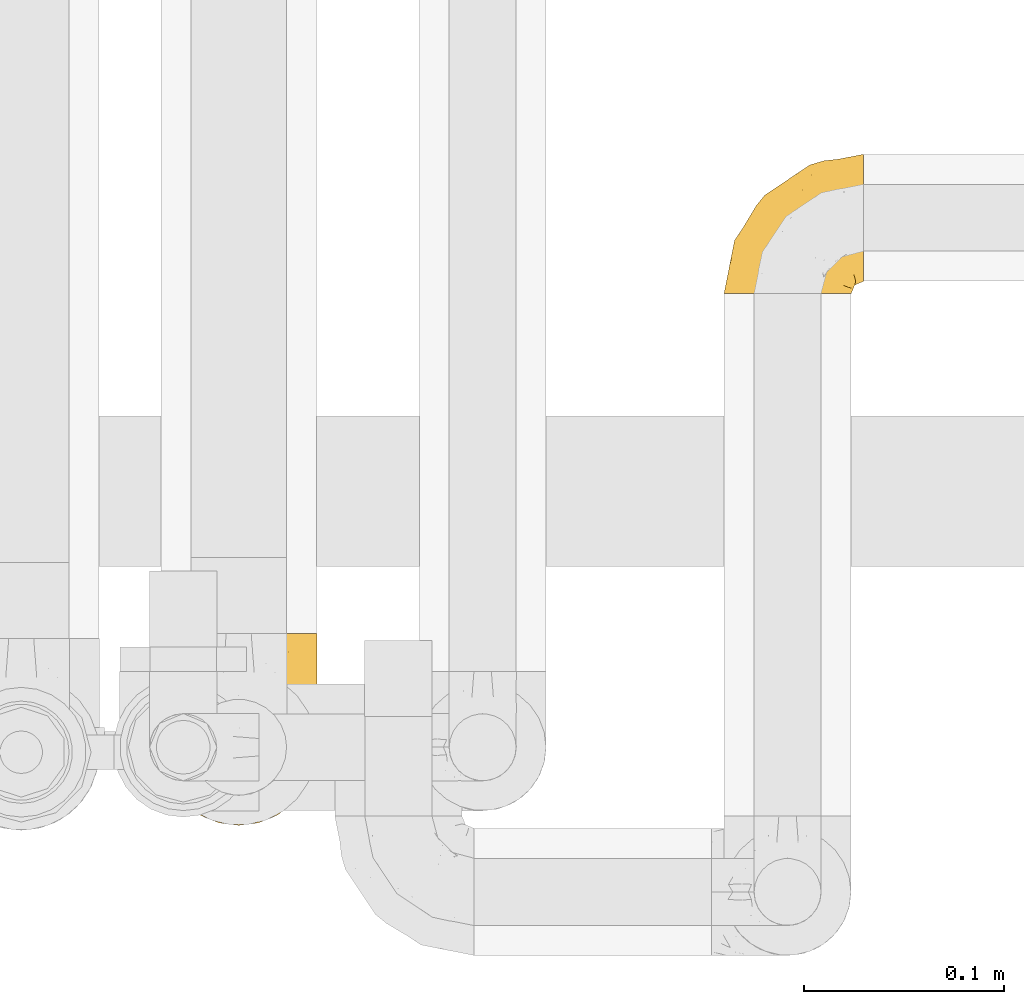
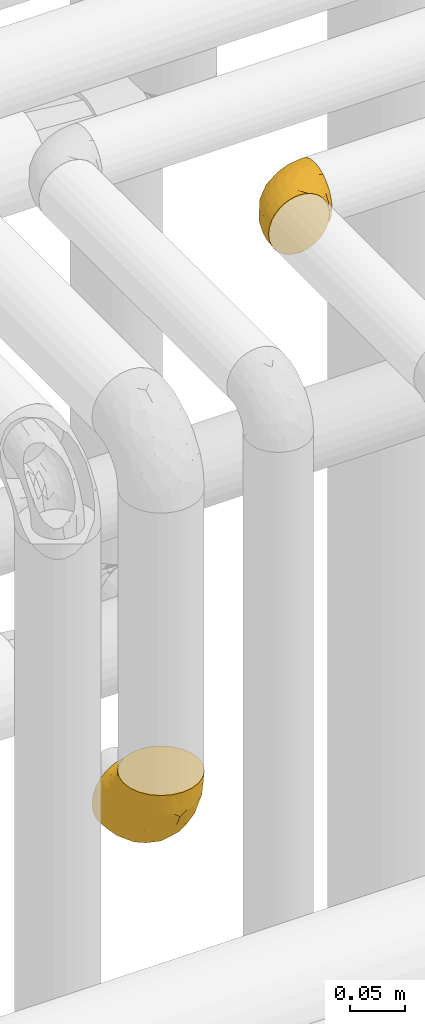
# One storey, part 450 of 827: 2 coverings.
"""IFC2X3 building model written with IfcOpenShell, lengths in millimetres."""

from ifc_helpers import new_model, entity, si_unit, converted_unit, derived_unit, direction, frame, origin, place, context, subcontext, project, spatial, faceted_brep, element, save


model = new_model("IFC2X3")

# Units and contexts
model_context = context("Model", 3, precision=0.01, world=origin(), true_north=direction((6.12303176911189e-17, 1.0)))
body_context = subcontext(model_context, "Body", "Model", "MODEL_VIEW")
ifc_project = project(units=[si_unit("LENGTHUNIT", "METRE", prefix="MILLI"), si_unit("AREAUNIT", "SQUARE_METRE"), si_unit("VOLUMEUNIT", "CUBIC_METRE"), converted_unit("PLANEANGLEUNIT", "DEGREE", entity("IfcRatioMeasure", 0.0174532925199433), si_unit("PLANEANGLEUNIT", "RADIAN"), dimensions=[0, 0, 0, 0, 0, 0, 0]), si_unit("MASSUNIT", "GRAM", prefix="KILO"), derived_unit("MASSDENSITYUNIT", [(si_unit("MASSUNIT", "GRAM", prefix="KILO"), 1), (si_unit("LENGTHUNIT", "METRE"), -3)]), derived_unit("MOMENTOFINERTIAUNIT", [(si_unit("LENGTHUNIT", "METRE"), 4)]), si_unit("TIMEUNIT", "SECOND"), si_unit("FREQUENCYUNIT", "HERTZ"), si_unit("THERMODYNAMICTEMPERATUREUNIT", "DEGREE_CELSIUS"), derived_unit("THERMALTRANSMITTANCEUNIT", [(si_unit("MASSUNIT", "GRAM", prefix="KILO"), 1), (si_unit("THERMODYNAMICTEMPERATUREUNIT", "KELVIN"), -1), (si_unit("TIMEUNIT", "SECOND"), -3)]), derived_unit("VOLUMETRICFLOWRATEUNIT", [(si_unit("LENGTHUNIT", "METRE"), 3), (si_unit("TIMEUNIT", "SECOND"), -1)]), derived_unit("MASSFLOWRATEUNIT", [(si_unit("MASSUNIT", "GRAM", prefix="KILO"), 1), (si_unit("TIMEUNIT", "SECOND"), -1)]), derived_unit("ROTATIONALFREQUENCYUNIT", [(si_unit("TIMEUNIT", "SECOND"), -1)]), si_unit("ELECTRICCURRENTUNIT", "AMPERE"), si_unit("ELECTRICVOLTAGEUNIT", "VOLT"), si_unit("POWERUNIT", "WATT"), si_unit("FORCEUNIT", "NEWTON", prefix="KILO"), si_unit("ILLUMINANCEUNIT", "LUX"), si_unit("LUMINOUSFLUXUNIT", "LUMEN"), si_unit("LUMINOUSINTENSITYUNIT", "CANDELA"), derived_unit("USERDEFINED", [(si_unit("MASSUNIT", "GRAM", prefix="KILO"), -1), (si_unit("LENGTHUNIT", "METRE"), -2), (si_unit("TIMEUNIT", "SECOND"), 3), (si_unit("LUMINOUSFLUXUNIT", "LUMEN"), 1)]), derived_unit("LINEARVELOCITYUNIT", [(si_unit("LENGTHUNIT", "METRE"), 1), (si_unit("TIMEUNIT", "SECOND"), -1)]), si_unit("PRESSUREUNIT", "PASCAL"), derived_unit("USERDEFINED", [(si_unit("LENGTHUNIT", "METRE"), -2), (si_unit("MASSUNIT", "GRAM", prefix="KILO"), 1), (si_unit("TIMEUNIT", "SECOND"), -2)]), derived_unit("LINEARFORCEUNIT", [(si_unit("MASSUNIT", "GRAM", prefix="KILO"), 1), (si_unit("LENGTHUNIT", "METRE"), 1), (si_unit("TIMEUNIT", "SECOND"), -2), (si_unit("LENGTHUNIT", "METRE"), -1)]), derived_unit("PLANARFORCEUNIT", [(si_unit("MASSUNIT", "GRAM", prefix="KILO"), 1), (si_unit("LENGTHUNIT", "METRE"), 1), (si_unit("TIMEUNIT", "SECOND"), -2), (si_unit("LENGTHUNIT", "METRE"), -2)])], contexts=[model_context])

# Site, building, storey
site_placement = place(None, origin())
site = spatial("IfcSite", under=ifc_project, at=site_placement, CompositionType="ELEMENT")
building_placement = place(site_placement, origin())
building = spatial("IfcBuilding", under=site, at=building_placement, CompositionType="ELEMENT")
storey_placement = place(building_placement, frame((0.0, 0.0, 28200.0)))
storey = spatial("IfcBuildingStorey", under=building, at=storey_placement, Name="08", CompositionType="ELEMENT", Elevation=28200.0)

# Coverings
covering_1_placement = place(storey_placement, frame((55802.39, 16229.69, 2734.25)))
element("IfcCovering", 1, at=covering_1_placement, inside=storey, Name=":ADSK_", ObjectType=":ADSK_", PredefinedType="INSULATION", context=body_context, shape_type="Brep", body=[
    faceted_brep([(79.9, 97.75, 40.75), (78.91, 97.75, 32.03), (76.02, 97.75, 23.75), (71.35, 97.75, 16.33), (65.15, 97.75, 10.13), (57.73, 97.75, 5.47), (49.45, 97.75, 2.58), (40.75, 97.75, 1.6), (32.03, 97.75, 2.58), (23.75, 97.75, 5.48), (16.33, 97.75, 10.14), (10.13, 97.75, 16.34), (5.47, 97.75, 23.76), (2.58, 97.75, 32.04), (1.6, 97.75, 40.75), (1.96, 97.75, 43.94), (2.58, 97.75, 49.46), (4.03, 97.75, 53.6), (5.48, 97.75, 57.74), (10.14, 97.75, 65.16), (16.34, 97.75, 71.36), (23.76, 97.75, 76.02), (32.04, 97.75, 78.91), (40.75, 97.75, 79.9), (49.46, 97.75, 78.91), (57.74, 97.75, 76.02), (65.16, 97.75, 71.35), (71.36, 97.75, 65.15), (76.02, 97.75, 57.73), (78.91, 97.75, 49.45), (79.54, 97.75, 43.94), (13.06, 68.43, 97.75), (6.84, 60.32, 97.75), (2.93, 50.88, 97.75), (2.44, 47.16, 97.75), (2.02, 43.95, 97.75), (1.6, 40.75, 97.75), (2.93, 30.61, 97.75), (6.84, 21.17, 97.75), (13.06, 13.06, 97.75), (21.17, 6.84, 97.75), (30.61, 2.93, 97.75), (40.75, 1.6, 97.75), (50.88, 2.93, 97.75), (60.32, 6.84, 97.75), (68.43, 13.06, 97.75), (74.65, 21.17, 97.75), (78.56, 30.61, 97.75), (79.9, 40.75, 97.75), (79.05, 47.16, 97.75), (78.56, 50.88, 97.75), (74.65, 60.32, 97.75), (68.43, 68.43, 97.75), (60.32, 74.65, 97.75), (50.88, 78.56, 97.75), (40.75, 79.9, 97.75), (30.61, 78.56, 97.75), (21.17, 74.65, 97.75), (40.75, 30.59, 30.59), (40.75, 41.23, 19.96), (53.99, 31.39, 31.39), (40.75, 19.96, 41.23), (40.75, 6.3, 68.03), (47.49, 5.21, 73.86), (40.75, 4.64, 78.49), (51.52, 15.42, 51.06), (61.86, 15.6, 61.05), (54.43, 6.88, 74.96), (63.37, 10.45, 80.64), (79.25, 80.79, 35.94), (77.04, 39.87, 55.44), (75.79, 25.91, 78.19), (72.61, 28.57, 58.08), (78.93, 35.0, 78.4), (70.12, 18.15, 74.65), (66.7, 74.57, 14.61), (72.7, 80.38, 20.05), (70.21, 59.65, 24.25), (78.8, 59.36, 43.81), (79.9, 75.93, 45.08), (79.9, 71.31, 48.17), (79.9, 66.69, 51.26), (79.9, 62.06, 54.35), (79.9, 57.44, 57.44), (74.44, 46.63, 40.25), (52.47, 74.83, 6.22), (79.33, 45.67, 61.23), (79.9, 54.35, 62.06), (79.9, 51.26, 66.69), (79.9, 48.17, 71.31), (79.9, 45.08, 75.93), (48.94, 54.03, 13.08), (58.78, 58.15, 14.98), (60.43, 80.8, 8.5), (40.75, 78.49, 4.64), (62.02, 31.82, 36.67), (57.53, 43.52, 22.97), (79.9, 94.17, 41.46), (79.9, 90.6, 42.17), (79.9, 83.46, 43.59), (64.12, 47.16, 25.24), (75.76, 64.11, 31.25), (76.65, 81.54, 26.96), (68.92, 38.43, 38.0), (66.73, 25.45, 50.65), (40.75, 13.13, 54.63), (40.75, 68.03, 6.3), (79.9, 43.59, 83.46), (79.9, 42.88, 87.03), (79.9, 42.17, 90.6), (40.75, 54.63, 13.13), (63.86, 73.05, 91.79), (69.15, 69.6, 87.2), (78.65, 51.66, 87.5), (72.98, 63.89, 89.79), (76.47, 57.82, 88.45), (76.82, 59.13, 81.77), (79.05, 52.25, 79.81), (79.09, 54.86, 73.84), (51.28, 79.38, 91.84), (51.03, 82.07, 86.62), (40.75, 85.12, 85.12), (40.75, 82.63, 91.15), (49.93, 89.2, 80.84), (58.53, 86.06, 78.96), (69.86, 81.78, 71.38), (65.19, 81.63, 76.81), (70.75, 76.19, 74.29), (79.25, 90.86, 48.29), (79.11, 85.89, 49.97), (57.89, 76.5, 92.85), (55.93, 92.32, 77.55), (78.06, 70.11, 62.05), (75.39, 69.83, 70.85), (78.16, 65.67, 65.52), (66.62, 76.0, 80.71), (73.14, 68.84, 77.97), (71.07, 91.37, 66.14), (78.32, 76.37, 57.01), (73.93, 83.17, 64.57), (77.25, 85.98, 56.53), (79.26, 79.95, 51.07), (60.3, 81.01, 81.85), (40.75, 91.15, 82.63), (65.72, 88.52, 72.53), (74.5, 75.86, 67.69), (60.62, 77.41, 86.44), (73.96, 64.86, 82.44), (77.3, 60.69, 75.97), (77.83, 62.7, 70.39), (23.6, 76.5, 92.85), (17.57, 73.85, 88.99), (1.6, 94.17, 41.46), (1.6, 90.6, 42.17), (1.6, 83.46, 43.59), (31.57, 89.2, 80.84), (22.97, 86.06, 78.97), (25.57, 92.32, 77.55), (15.78, 88.52, 72.54), (1.6, 43.59, 83.46), (1.6, 42.17, 90.6), (1.6, 41.46, 94.17), (12.34, 69.6, 87.2), (7.57, 64.84, 82.6), (8.85, 64.5, 89.34), (2.63, 52.81, 80.74), (4.67, 59.13, 81.77), (2.36, 54.5, 74.04), (1.6, 45.08, 75.93), (2.84, 51.66, 87.5), (2.24, 79.95, 51.07), (1.6, 71.31, 48.17), (3.18, 76.38, 57.03), (10.74, 76.18, 74.31), (15.18, 76.44, 80.61), (16.42, 81.43, 77.09), (30.21, 79.38, 91.84), (9.98, 70.71, 79.19), (30.46, 82.07, 86.62), (10.43, 91.37, 66.15), (12.05, 81.89, 71.84), (4.24, 85.98, 56.55), (7.56, 83.17, 64.59), (3.43, 70.11, 62.05), (2.38, 85.9, 49.99), (1.6, 75.93, 45.08), (3.66, 62.7, 70.39), (4.45, 61.23, 76.36), (6.98, 75.83, 67.71), (6.12, 69.82, 70.92), (5.38, 58.44, 89.33), (21.58, 81.13, 82.04), (3.35, 65.71, 65.56), (1.6, 62.06, 54.35), (20.87, 77.41, 86.44), (1.6, 54.35, 62.06), (1.6, 57.44, 57.44), (1.6, 48.17, 71.31), (1.6, 51.26, 66.69), (1.6, 66.69, 51.26), (2.16, 45.67, 61.23), (11.37, 18.15, 74.65), (5.7, 25.91, 78.19), (8.88, 28.58, 58.07), (12.57, 38.43, 38.01), (7.04, 46.64, 40.25), (11.27, 59.66, 24.26), (17.36, 47.16, 25.25), (2.69, 59.36, 43.81), (2.56, 35.0, 78.4), (34.0, 5.21, 73.86), (27.06, 6.88, 74.96), (4.45, 39.88, 55.45), (5.73, 64.12, 31.26), (18.12, 10.45, 80.64), (19.63, 15.6, 61.05), (27.49, 31.39, 31.39), (19.46, 31.82, 36.69), (2.24, 80.8, 35.95), (29.01, 74.83, 6.22), (14.78, 74.57, 14.62), (32.55, 54.02, 13.09), (8.78, 80.38, 20.06), (29.98, 15.42, 51.06), (23.95, 43.52, 22.97), (22.7, 58.15, 14.99), (21.05, 80.8, 8.51), (14.75, 25.47, 50.64), (4.84, 81.54, 26.97)], [[[0, 1, 2, 3, 4, 5, 6, 7, 8, 9, 10, 11, 12, 13, 14, 15, 16, 17, 18, 19, 20, 21, 22, 23, 24, 25, 26, 27, 28, 29, 30]], [[31, 32, 33, 34, 35, 36, 37, 38, 39, 40, 41, 42, 43, 44, 45, 46, 47, 48, 49, 50, 51, 52, 53, 54, 55, 56, 57]], [[58, 59, 60, 61]], [[62, 63, 64]], [[65, 66, 67]], [[67, 66, 68]], [[69, 1, 0]], [[70, 71, 72]], [[44, 43, 67]], [[47, 71, 73]], [[45, 74, 46]], [[68, 45, 44]], [[75, 76, 77]], [[76, 3, 2]], [[78, 79, 80, 81, 82, 83]], [[48, 47, 73]], [[70, 72, 84]], [[5, 85, 6]], [[86, 83, 87, 88, 89, 90]], [[91, 85, 92]], [[76, 75, 3]], [[71, 46, 74]], [[85, 5, 93]], [[45, 68, 74]], [[5, 4, 93]], [[85, 94, 6]], [[86, 78, 83]], [[60, 95, 65]], [[96, 95, 60]], [[75, 4, 3]], [[69, 0, 97, 98, 99, 79]], [[75, 77, 100]], [[43, 64, 63]], [[101, 102, 69]], [[101, 76, 102]], [[46, 71, 47]], [[95, 103, 104]], [[92, 85, 93]], [[63, 105, 65]], [[92, 75, 100]], [[91, 106, 85]], [[84, 78, 70]], [[67, 68, 44]], [[65, 67, 63]], [[65, 61, 60]], [[4, 75, 93]], [[92, 93, 75]], [[102, 76, 2]], [[77, 76, 101]], [[84, 77, 101]], [[77, 103, 100]], [[72, 71, 74]], [[70, 86, 73]], [[104, 74, 66]], [[84, 72, 103]], [[70, 73, 71]], [[73, 90, 107, 108, 109, 48]], [[79, 78, 69]], [[101, 69, 78]], [[91, 92, 96]], [[91, 59, 110, 106]], [[2, 1, 102]], [[69, 102, 1]], [[94, 85, 106]], [[94, 7, 6]], [[74, 68, 66]], [[43, 42, 64]], [[43, 63, 67]], [[73, 86, 90]], [[78, 86, 70]], [[95, 100, 103]], [[96, 92, 100]], [[104, 103, 72]], [[65, 95, 66]], [[74, 104, 72]], [[66, 95, 104]], [[95, 96, 100]], [[91, 96, 60]], [[77, 84, 103]], [[78, 84, 101]], [[60, 59, 91]], [[105, 63, 62]], [[105, 61, 65]], [[111, 52, 112]], [[107, 90, 113]], [[114, 115, 116]], [[50, 107, 113]], [[117, 118, 116]], [[54, 119, 55]], [[97, 0, 30, 29, 98]], [[113, 115, 51]], [[120, 121, 122]], [[123, 120, 124]], [[125, 126, 127]], [[128, 28, 129]], [[130, 54, 53]], [[25, 24, 131]], [[132, 133, 134]], [[135, 112, 136]], [[137, 27, 26]], [[121, 120, 123]], [[138, 139, 132]], [[129, 140, 141]], [[135, 126, 142]], [[27, 140, 28]], [[27, 137, 140]], [[49, 48, 109, 108, 107, 50]], [[23, 143, 121, 123]], [[25, 131, 144]], [[26, 25, 144]], [[128, 98, 29]], [[125, 127, 145]], [[146, 130, 111]], [[137, 144, 139]], [[139, 138, 140]], [[116, 147, 114]], [[123, 124, 131]], [[116, 118, 148]], [[138, 132, 81]], [[129, 79, 99]], [[54, 130, 119]], [[141, 79, 129]], [[122, 55, 119]], [[120, 146, 142]], [[117, 113, 90]], [[50, 113, 51]], [[127, 133, 145]], [[147, 136, 112]], [[136, 133, 127]], [[24, 23, 123]], [[118, 117, 89]], [[149, 87, 134]], [[144, 131, 124]], [[24, 123, 131]], [[128, 129, 99]], [[28, 140, 129]], [[144, 137, 26]], [[140, 137, 139]], [[134, 82, 132]], [[138, 80, 141]], [[89, 88, 87, 118]], [[115, 117, 116]], [[140, 138, 141]], [[148, 118, 149]], [[136, 148, 149]], [[147, 116, 148]], [[133, 136, 149]], [[127, 126, 135]], [[136, 147, 148]], [[114, 112, 52]], [[112, 114, 147]], [[51, 114, 52]], [[51, 115, 114]], [[117, 115, 113]], [[117, 90, 89]], [[134, 133, 149]], [[145, 133, 132]], [[132, 139, 145]], [[125, 139, 144]], [[139, 125, 145]], [[126, 144, 124]], [[144, 126, 125]], [[142, 126, 124]], [[120, 142, 124]], [[142, 146, 135]], [[112, 135, 146]], [[136, 127, 135]], [[118, 87, 149]], [[111, 130, 53]], [[119, 146, 120]], [[146, 119, 130]], [[122, 119, 120]], [[52, 111, 53]], [[146, 111, 112]], [[82, 134, 83]], [[82, 81, 132]], [[83, 134, 87]], [[98, 128, 99]], [[80, 138, 81]], [[80, 79, 141]], [[28, 128, 29]], [[150, 151, 57]], [[15, 14, 152, 153, 154, 16]], [[121, 143, 23, 155]], [[150, 57, 56]], [[156, 157, 158]], [[35, 34, 33, 159, 160, 161, 36]], [[162, 31, 57]], [[163, 164, 162]], [[165, 166, 167]], [[155, 23, 22]], [[168, 159, 169]], [[170, 171, 172]], [[173, 174, 175]], [[55, 122, 176]], [[177, 174, 173]], [[22, 157, 155]], [[178, 121, 155]], [[169, 33, 32]], [[20, 19, 179]], [[21, 20, 158]], [[158, 180, 175]], [[181, 182, 179]], [[172, 183, 182]], [[122, 121, 178]], [[181, 19, 18]], [[184, 185, 170]], [[17, 154, 184]], [[186, 187, 177]], [[187, 186, 167]], [[179, 158, 20]], [[21, 157, 22]], [[175, 180, 173]], [[188, 189, 173]], [[164, 166, 190]], [[185, 184, 154]], [[181, 172, 182]], [[156, 191, 178]], [[192, 183, 193]], [[178, 176, 122]], [[194, 150, 176]], [[33, 169, 159]], [[190, 169, 32]], [[189, 192, 186]], [[180, 188, 173]], [[167, 166, 187]], [[166, 164, 163]], [[195, 192, 196]], [[158, 157, 21]], [[155, 157, 156]], [[178, 155, 156]], [[181, 18, 184]], [[17, 16, 154]], [[181, 179, 19]], [[158, 179, 182]], [[170, 181, 184]], [[192, 195, 186]], [[31, 190, 32]], [[165, 190, 166]], [[190, 31, 164]], [[31, 162, 164]], [[177, 163, 162]], [[187, 166, 163]], [[151, 174, 177]], [[177, 173, 189]], [[177, 187, 163]], [[195, 167, 186]], [[165, 197, 168]], [[165, 168, 169]], [[167, 197, 165]], [[190, 165, 169]], [[167, 195, 198, 197]], [[151, 177, 162]], [[175, 191, 156]], [[191, 174, 194]], [[158, 175, 156]], [[174, 191, 175]], [[178, 191, 194]], [[158, 182, 180]], [[188, 182, 183]], [[182, 188, 180]], [[183, 192, 189]], [[183, 189, 188]], [[177, 189, 186]], [[183, 199, 193]], [[176, 150, 56]], [[151, 150, 194]], [[176, 56, 55]], [[194, 176, 178]], [[174, 151, 194]], [[57, 151, 162]], [[199, 183, 172]], [[196, 192, 193]], [[171, 199, 172]], [[172, 181, 170]], [[170, 185, 171]], [[184, 18, 17]], [[200, 168, 197, 198, 195, 196]], [[201, 202, 203]], [[204, 203, 205]], [[204, 206, 207]], [[208, 196, 193, 199, 171, 185]], [[209, 36, 161, 160, 159, 168]], [[202, 38, 37]], [[201, 38, 202]], [[210, 41, 211]], [[200, 208, 212]], [[205, 208, 213]], [[214, 211, 40]], [[40, 211, 41]], [[214, 201, 215]], [[58, 61, 216, 59]], [[201, 39, 38]], [[207, 217, 204]], [[213, 208, 218]], [[218, 185, 154, 153, 152, 14]], [[14, 13, 218]], [[9, 8, 219]], [[10, 220, 11]], [[221, 106, 110, 59]], [[219, 8, 94]], [[220, 222, 11]], [[223, 211, 215]], [[221, 216, 224]], [[225, 219, 221]], [[10, 9, 226]], [[213, 222, 206]], [[226, 9, 219]], [[106, 219, 94]], [[212, 202, 209]], [[201, 203, 227]], [[226, 225, 220]], [[207, 206, 220]], [[214, 40, 39]], [[11, 222, 12]], [[12, 222, 228]], [[41, 210, 64]], [[223, 105, 210]], [[223, 215, 217]], [[105, 62, 210]], [[206, 222, 220]], [[228, 222, 213]], [[207, 220, 225]], [[205, 206, 204]], [[225, 226, 219]], [[220, 10, 226]], [[209, 202, 37]], [[203, 202, 212]], [[205, 203, 212]], [[204, 217, 227]], [[36, 209, 37]], [[209, 168, 200]], [[218, 13, 228]], [[208, 185, 218]], [[106, 221, 219]], [[221, 59, 216]], [[218, 228, 213]], [[13, 12, 228]], [[8, 7, 94]], [[201, 214, 39]], [[211, 214, 215]], [[64, 210, 62]], [[64, 42, 41]], [[223, 210, 211]], [[208, 200, 196]], [[209, 200, 212]], [[225, 224, 207]], [[207, 224, 217]], [[223, 217, 216]], [[204, 227, 203]], [[217, 215, 227]], [[201, 227, 215]], [[221, 224, 225]], [[217, 224, 216]], [[208, 205, 212]], [[206, 205, 213]], [[216, 61, 223]], [[223, 61, 105]]]),
])
covering_2_placement = place(storey_placement, frame((56084.69, 16496.1, 3166.55)))
element("IfcCovering", 2, at=covering_2_placement, inside=storey, Name=":ADSK_", ObjectType=":ADSK_", PredefinedType="INSULATION", context=body_context, shape_type="Brep", body=[
    faceted_brep([(2.39, 1.6, 40.53), (1.6, 1.6, 33.45), (2.39, 1.6, 26.35), (4.75, 1.6, 19.62), (8.55, 1.6, 13.58), (13.59, 1.6, 8.54), (19.63, 1.6, 4.75), (26.36, 1.6, 2.39), (33.45, 1.6, 1.6), (37.35, 1.6, 2.04), (40.54, 1.6, 2.39), (43.9, 1.6, 3.57), (47.27, 1.6, 4.75), (53.31, 1.6, 8.55), (58.35, 1.6, 13.59), (62.14, 1.6, 19.63), (64.5, 1.6, 26.36), (65.3, 1.6, 33.45), (64.5, 1.6, 40.54), (62.14, 1.6, 47.27), (58.34, 1.6, 53.31), (53.3, 1.6, 58.35), (47.26, 1.6, 62.14), (43.89, 1.6, 63.32), (40.53, 1.6, 64.5), (37.35, 1.6, 64.86), (35.4, 1.6, 65.08), (33.45, 1.6, 65.3), (26.35, 1.6, 64.5), (19.62, 1.6, 62.14), (13.58, 1.6, 58.34), (8.54, 1.6, 53.3), (4.75, 1.6, 47.26), (71.45, 23.67, 5.86), (71.45, 27.51, 4.27), (71.45, 31.35, 2.68), (71.45, 35.67, 2.11), (71.45, 37.63, 1.85), (71.45, 39.6, 1.6), (71.45, 47.84, 2.68), (71.45, 55.52, 5.86), (71.45, 62.12, 10.92), (71.45, 67.18, 17.52), (71.45, 70.36, 25.2), (71.45, 71.45, 33.45), (71.45, 70.36, 41.69), (71.45, 67.18, 49.37), (71.45, 62.12, 55.97), (71.45, 55.52, 61.03), (71.45, 47.84, 64.21), (71.45, 39.6, 65.3), (71.45, 35.67, 64.78), (71.45, 31.35, 64.21), (71.45, 27.51, 62.62), (71.45, 23.67, 61.03), (71.45, 20.37, 58.5), (71.45, 17.07, 55.97), (71.45, 12.01, 49.37), (71.45, 8.83, 41.69), (71.45, 7.75, 33.45), (71.45, 8.83, 25.2), (71.45, 12.01, 17.52), (71.45, 17.07, 10.92), (71.45, 20.37, 8.39), (37.48, 33.94, 64.03), (38.54, 20.6, 65.3), (42.01, 24.07, 65.3), (45.49, 27.55, 65.3), (48.97, 31.03, 65.3), (52.45, 34.5, 65.3), (58.08, 68.79, 33.45), (40.84, 53.62, 56.13), (47.91, 50.17, 61.0), (55.67, 58.62, 57.25), (55.18, 67.51, 44.44), (45.13, 61.03, 50.33), (59.19, 64.5, 51.72), (11.67, 17.98, 54.4), (38.17, 61.71, 41.87), (28.82, 52.25, 48.25), (29.48, 16.72, 64.6), (32.11, 39.09, 60.78), (24.68, 25.86, 61.71), (55.82, 44.07, 64.46), (28.37, 44.36, 55.78), (9.18, 31.35, 40.71), (4.95, 17.72, 42.87), (11.17, 29.45, 47.87), (60.89, 52.37, 62.12), (55.35, 35.28, 65.3), (58.25, 36.06, 65.3), (61.15, 36.84, 65.3), (64.05, 37.61, 65.3), (65.9, 38.11, 65.3), (67.75, 38.61, 65.3), (16.27, 14.07, 59.32), (6.97, 13.65, 49.35), (4.25, 14.96, 33.45), (21.84, 13.32, 62.53), (33.94, 3.44, 65.3), (34.44, 5.29, 65.3), (35.43, 8.99, 65.3), (36.2, 11.89, 65.3), (36.98, 14.79, 65.3), (37.76, 17.69, 65.3), (18.84, 29.19, 57.03), (14.39, 28.91, 52.84), (51.68, 68.17, 38.52), (6.91, 28.33, 33.45), (26.05, 53.45, 41.09), (33.38, 58.56, 33.45), (22.05, 50.99, 33.45), (17.7, 43.14, 44.35), (19.21, 39.23, 51.29), (44.71, 66.13, 33.45), (17.7, 45.6, 38.44), (14.48, 39.66, 33.45), (66.98, 18.04, 57.42), (65.01, 22.76, 61.06), (61.98, 21.95, 61.24), (64.85, 32.18, 64.58), (62.15, 29.08, 64.0), (48.67, 20.77, 64.21), (63.81, 4.75, 44.85), (50.71, 11.03, 61.42), (48.45, 6.78, 61.84), (52.85, 5.68, 59.03), (67.6, 7.71, 41.64), (65.48, 4.42, 38.8), (67.1, 5.94, 33.45), (66.68, 14.52, 54.12), (43.2, 11.63, 64.27), (44.92, 6.6, 63.33), (58.1, 7.33, 54.97), (61.92, 12.48, 54.91), (63.17, 7.99, 49.44), (66.68, 11.14, 49.79), (56.7, 14.07, 59.23), (50.86, 15.37, 62.42), (54.42, 10.81, 59.27), (40.7, 7.89, 64.6), (57.76, 26.18, 63.73), (61.34, 5.8, 50.25), (59.9, 9.94, 54.66), (58.0, 22.23, 62.35), (62.43, 18.39, 59.05), (45.83, 17.71, 64.34), (58.99, 16.87, 59.52), (45.9, 13.24, 63.71), (67.3, 24.95, 61.92), (53.12, 26.59, 64.52), (49.43, 26.16, 64.9), (53.9, 22.11, 63.33), (52.92, 17.43, 62.23), (63.81, 4.75, 22.04), (61.35, 5.8, 16.65), (63.17, 7.99, 17.46), (56.72, 14.07, 7.66), (59.87, 10.06, 12.13), (54.39, 11.54, 7.35), (67.59, 7.71, 25.25), (40.71, 7.89, 2.29), (35.43, 8.99, 1.6), (36.2, 11.89, 1.6), (36.98, 14.79, 1.6), (65.48, 4.42, 28.1), (58.19, 22.42, 4.51), (55.78, 27.95, 2.45), (62.46, 22.22, 5.62), (69.6, 39.1, 1.6), (61.15, 36.84, 1.6), (64.05, 37.61, 1.6), (67.75, 38.61, 1.6), (67.39, 21.49, 6.96), (66.16, 26.52, 4.16), (58.11, 18.09, 6.38), (62.44, 18.39, 7.84), (61.95, 13.88, 10.87), (66.68, 11.14, 17.1), (64.85, 32.18, 2.31), (52.45, 34.5, 1.6), (48.97, 31.03, 1.6), (43.18, 11.65, 2.62), (52.88, 5.67, 7.88), (48.46, 6.81, 5.05), (34.44, 5.29, 1.6), (34.93, 7.14, 1.6), (58.11, 7.34, 11.92), (58.25, 36.06, 1.6), (60.72, 31.38, 2.23), (49.13, 19.83, 2.95), (45.49, 27.55, 1.6), (53.71, 22.94, 3.29), (44.93, 6.6, 3.56), (67.04, 17.93, 9.57), (66.6, 14.52, 12.74), (44.91, 17.45, 2.39), (50.72, 11.03, 5.47), (37.76, 17.69, 1.6), (38.54, 20.6, 1.6), (46.39, 12.33, 3.46), (57.7, 30.27, 2.2), (55.35, 35.28, 1.6), (62.73, 25.9, 4.02), (42.01, 24.07, 1.6), (55.67, 58.62, 9.64), (21.85, 13.32, 4.35), (29.49, 16.72, 2.29), (55.82, 44.07, 2.43), (38.17, 61.71, 25.02), (55.18, 67.51, 22.45), (45.12, 61.03, 16.56), (47.92, 50.18, 5.89), (37.47, 33.92, 2.86), (32.11, 39.08, 6.1), (40.85, 53.62, 10.76), (51.68, 68.17, 28.37), (60.89, 52.37, 4.77), (59.19, 64.5, 15.17), (24.69, 25.86, 5.18), (16.28, 14.07, 7.56), (18.85, 29.18, 9.85), (11.19, 29.46, 19.01), (4.95, 17.73, 24.01), (9.19, 31.37, 26.18), (11.68, 17.99, 12.48), (26.05, 53.45, 25.8), (19.23, 39.25, 15.6), (14.4, 28.92, 14.04), (6.97, 13.65, 17.53), (28.8, 52.23, 18.64), (17.7, 43.13, 22.54), (28.37, 44.36, 11.1), (17.7, 45.6, 28.45)], [[[0, 1, 2, 3, 4, 5, 6, 7, 8, 9, 10, 11, 12, 13, 14, 15, 16, 17, 18, 19, 20, 21, 22, 23, 24, 25, 26, 27, 28, 29, 30, 31, 32]], [[33, 34, 35, 36, 37, 38, 39, 40, 41, 42, 43, 44, 45, 46, 47, 48, 49, 50, 51, 52, 53, 54, 55, 56, 57, 58, 59, 60, 61, 62, 63]], [[64, 65, 66, 67, 68, 69]], [[45, 44, 70]], [[71, 72, 73]], [[74, 75, 76]], [[77, 31, 30]], [[75, 78, 79]], [[27, 80, 28]], [[74, 46, 45]], [[64, 81, 82]], [[46, 76, 47]], [[83, 50, 49]], [[48, 47, 73]], [[71, 79, 84]], [[85, 86, 87]], [[49, 48, 88]], [[83, 69, 89, 90, 91, 92, 93, 94, 50]], [[95, 77, 30]], [[75, 74, 78]], [[87, 86, 96]], [[96, 86, 32]], [[96, 32, 31]], [[0, 86, 97]], [[83, 64, 69]], [[98, 80, 82]], [[73, 72, 88]], [[64, 80, 65]], [[1, 0, 97]], [[80, 27, 99, 100, 101, 102, 103, 104, 65]], [[77, 105, 106]], [[64, 82, 80]], [[70, 107, 45]], [[77, 95, 105]], [[82, 95, 98]], [[95, 30, 29]], [[74, 107, 78]], [[86, 0, 32]], [[72, 71, 81]], [[85, 108, 86]], [[76, 73, 47]], [[71, 84, 81]], [[109, 110, 111]], [[87, 112, 85]], [[79, 109, 112]], [[79, 112, 113]], [[88, 83, 49]], [[64, 83, 72]], [[31, 77, 96]], [[87, 96, 77]], [[98, 95, 29]], [[105, 95, 82]], [[81, 105, 82]], [[105, 84, 113]], [[29, 28, 98]], [[114, 107, 70]], [[80, 98, 28]], [[73, 75, 71]], [[79, 71, 75]], [[74, 76, 46]], [[73, 76, 75]], [[78, 107, 114]], [[45, 107, 74]], [[87, 113, 112]], [[115, 85, 112]], [[109, 79, 78]], [[113, 87, 106]], [[116, 115, 111]], [[116, 108, 85]], [[79, 113, 84]], [[109, 78, 110]], [[115, 109, 111]], [[85, 115, 116]], [[109, 115, 112]], [[72, 81, 64]], [[105, 81, 84]], [[73, 88, 48]], [[83, 88, 72]], [[86, 108, 97]], [[78, 114, 110]], [[113, 106, 105]], [[87, 77, 106]], [[117, 118, 119]], [[52, 120, 54, 53]], [[91, 120, 52]], [[91, 90, 120]], [[90, 121, 120]], [[122, 67, 66]], [[18, 123, 19]], [[124, 125, 126]], [[127, 59, 58]], [[128, 129, 127]], [[130, 57, 117]], [[131, 132, 125]], [[19, 133, 20]], [[128, 18, 17]], [[134, 135, 136]], [[137, 138, 139]], [[131, 103, 140]], [[22, 140, 23]], [[131, 65, 104, 103]], [[99, 27, 26, 25, 24, 101, 100]], [[141, 118, 121]], [[19, 123, 142]], [[52, 51, 50, 94, 93, 92, 91]], [[129, 128, 17]], [[117, 56, 118]], [[135, 134, 143]], [[139, 126, 133]], [[119, 144, 145]], [[127, 135, 123]], [[136, 58, 57]], [[101, 24, 23]], [[124, 138, 146]], [[140, 101, 23]], [[145, 147, 134]], [[140, 132, 131]], [[140, 103, 102, 101]], [[140, 22, 132]], [[146, 148, 124]], [[121, 69, 141]], [[55, 149, 118]], [[150, 151, 152]], [[147, 137, 134]], [[144, 150, 152]], [[152, 151, 122]], [[138, 122, 146]], [[59, 127, 129]], [[123, 18, 128]], [[58, 136, 127]], [[135, 127, 136]], [[121, 90, 89, 69]], [[120, 121, 149]], [[122, 66, 146]], [[153, 122, 138]], [[141, 69, 68]], [[127, 123, 128]], [[123, 135, 142]], [[143, 142, 135]], [[19, 142, 133]], [[66, 65, 146]], [[148, 65, 131]], [[22, 21, 132]], [[125, 132, 21]], [[126, 125, 21]], [[148, 125, 124]], [[21, 20, 126]], [[133, 126, 20]], [[139, 138, 124]], [[153, 138, 137]], [[126, 139, 124]], [[139, 133, 143]], [[147, 153, 137]], [[152, 122, 153]], [[134, 136, 130]], [[137, 139, 143]], [[144, 147, 145]], [[153, 147, 152]], [[65, 148, 146]], [[125, 148, 131]], [[141, 144, 119]], [[55, 54, 149]], [[137, 143, 134]], [[142, 143, 133]], [[130, 117, 145]], [[57, 56, 117]], [[134, 130, 145]], [[57, 130, 136]], [[150, 144, 141]], [[147, 144, 152]], [[141, 68, 150]], [[151, 68, 67]], [[117, 119, 145]], [[141, 119, 118]], [[68, 151, 150]], [[122, 151, 67]], [[118, 56, 55]], [[120, 149, 54]], [[118, 149, 121]], [[154, 155, 156]], [[157, 158, 159]], [[129, 160, 59]], [[161, 162, 163, 164]], [[165, 160, 129]], [[166, 167, 168]], [[169, 38, 37, 36, 35, 170, 171, 172]], [[63, 173, 174]], [[175, 176, 177]], [[60, 178, 61]], [[179, 35, 34, 33]], [[160, 60, 59]], [[180, 167, 181]], [[129, 17, 165]], [[182, 161, 164]], [[183, 13, 184]], [[9, 8, 185, 186, 162, 10]], [[187, 155, 15]], [[188, 179, 189]], [[187, 15, 14]], [[190, 191, 192]], [[182, 193, 161]], [[194, 176, 168]], [[176, 195, 177]], [[196, 190, 197]], [[11, 10, 162]], [[11, 161, 12]], [[187, 14, 183]], [[12, 161, 193]], [[156, 158, 177]], [[165, 17, 16]], [[194, 195, 176]], [[187, 159, 158]], [[179, 174, 189]], [[182, 164, 198, 199]], [[200, 199, 196]], [[193, 184, 13]], [[194, 168, 173]], [[201, 202, 189]], [[16, 154, 165]], [[160, 156, 178]], [[160, 165, 154]], [[178, 60, 160]], [[170, 35, 179]], [[188, 170, 179]], [[189, 174, 203]], [[174, 179, 33]], [[201, 189, 203]], [[181, 192, 191]], [[167, 180, 201]], [[192, 175, 190]], [[159, 190, 157]], [[15, 154, 16]], [[204, 196, 199]], [[204, 191, 190]], [[160, 154, 156]], [[15, 155, 154]], [[158, 155, 187]], [[203, 173, 168]], [[192, 181, 167]], [[190, 196, 204]], [[200, 196, 197]], [[184, 193, 182]], [[13, 12, 193]], [[200, 184, 182]], [[184, 200, 183]], [[187, 183, 197]], [[14, 13, 183]], [[162, 161, 11]], [[63, 62, 173]], [[174, 33, 63]], [[173, 62, 194]], [[174, 173, 203]], [[62, 61, 194]], [[195, 61, 178]], [[61, 195, 194]], [[177, 195, 178]], [[156, 177, 178]], [[175, 192, 166]], [[166, 168, 176]], [[167, 203, 168]], [[175, 166, 176]], [[167, 166, 192]], [[177, 157, 175]], [[190, 175, 157]], [[187, 197, 159]], [[190, 159, 197]], [[177, 158, 157]], [[155, 158, 156]], [[167, 201, 203]], [[200, 197, 183]], [[202, 201, 180]], [[202, 188, 189]], [[199, 200, 182]], [[41, 40, 205]], [[206, 207, 7]], [[208, 38, 169, 172, 171, 170, 188, 202, 180]], [[209, 210, 211]], [[212, 213, 214]], [[212, 215, 205]], [[43, 210, 216]], [[217, 40, 39]], [[216, 114, 70]], [[208, 213, 212]], [[205, 40, 217]], [[218, 42, 41]], [[216, 209, 114]], [[42, 218, 210]], [[214, 213, 219]], [[219, 220, 221]], [[199, 207, 213]], [[213, 207, 219]], [[8, 7, 207]], [[222, 223, 224]], [[4, 225, 5]], [[2, 97, 223]], [[110, 226, 111]], [[225, 220, 5]], [[227, 221, 228]], [[223, 229, 3]], [[2, 223, 3]], [[230, 231, 226]], [[224, 223, 108]], [[42, 210, 43]], [[230, 209, 211]], [[222, 225, 229]], [[38, 208, 39]], [[3, 229, 4]], [[213, 180, 181, 191, 204, 199]], [[220, 206, 6]], [[5, 220, 6]], [[207, 199, 198, 164, 163, 162, 186, 185, 8]], [[212, 214, 215]], [[218, 205, 211]], [[211, 215, 230]], [[226, 110, 209]], [[222, 231, 227]], [[222, 224, 231]], [[213, 208, 180]], [[217, 208, 212]], [[222, 229, 223]], [[225, 4, 229]], [[221, 220, 225]], [[206, 220, 219]], [[228, 221, 225]], [[214, 221, 232]], [[207, 206, 219]], [[44, 43, 70]], [[7, 6, 206]], [[230, 215, 232]], [[211, 205, 215]], [[205, 218, 41]], [[210, 218, 211]], [[43, 216, 70]], [[209, 216, 210]], [[233, 116, 111]], [[230, 232, 227]], [[224, 116, 233]], [[230, 226, 209]], [[224, 108, 116]], [[230, 227, 231]], [[221, 227, 232]], [[233, 226, 231]], [[225, 222, 228]], [[226, 233, 111]], [[224, 233, 231]], [[221, 214, 219]], [[214, 232, 215]], [[208, 217, 39]], [[205, 217, 212]], [[97, 2, 1]], [[97, 108, 223]], [[110, 114, 209]], [[227, 228, 222]]]),
])

save(model, "model.ifc")
